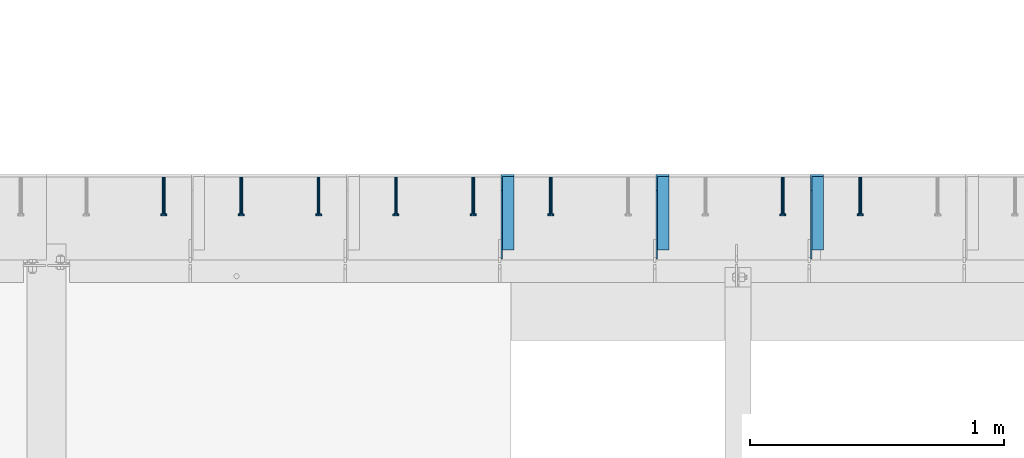
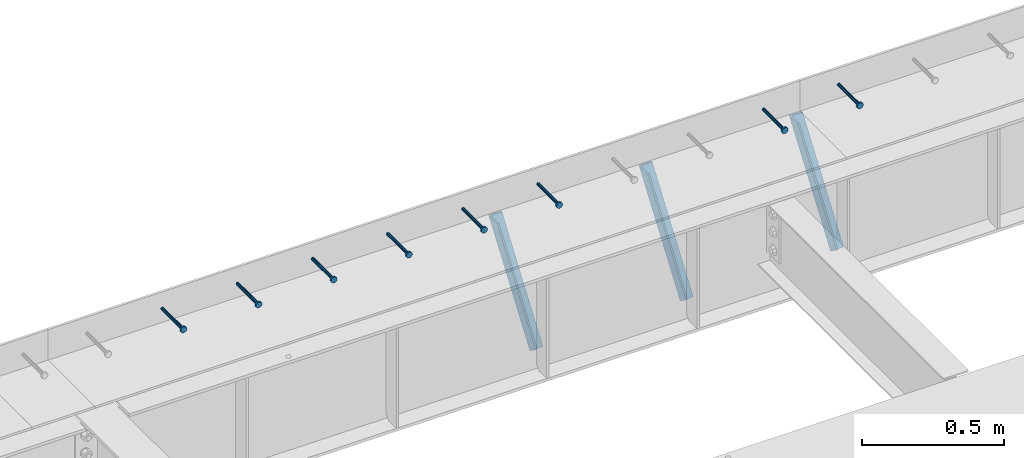
# One storey, part 1342 of 1763: 8 beams, 3 members, 9 elements without a shape of their own.
"""IFC2X3 building model written with IfcOpenShell, lengths in millimetres."""

from ifc_helpers import new_model, si_unit, frame, origin_with_axes, place, context, subcontext, project, spatial, faceted_brep, material, type_object, element, aggregate, save


model = new_model("IFC2X3")

# Units and contexts
model_context = context("Model", 3, precision=1e-05, world=origin_with_axes())
body_context = subcontext(model_context, "Body", "Model", "MODEL_VIEW")
ifc_project = project(units=[si_unit("LENGTHUNIT", "METRE", prefix="MILLI"), si_unit("AREAUNIT", "SQUARE_METRE"), si_unit("VOLUMEUNIT", "CUBIC_METRE"), si_unit("MASSUNIT", "GRAM", prefix="KILO"), si_unit("TIMEUNIT", "SECOND"), si_unit("PLANEANGLEUNIT", "RADIAN"), si_unit("SOLIDANGLEUNIT", "STERADIAN"), si_unit("THERMODYNAMICTEMPERATUREUNIT", "DEGREE_CELSIUS"), si_unit("LUMINOUSINTENSITYUNIT", "LUMEN")], contexts=[model_context])

# Site, building, storey
site_placement = place(None, origin_with_axes())
site = spatial("IfcSite", under=ifc_project, at=site_placement, CompositionType="ELEMENT")
building_placement = place(site_placement, origin_with_axes())
building = spatial("IfcBuilding", under=site, at=building_placement, Name="Undefined", CompositionType="ELEMENT")
storey_placement = place(building_placement, origin_with_axes())
storey = spatial("IfcBuildingStorey", under=building, at=storey_placement, Name="Undefined", CompositionType="ELEMENT", Elevation=0.0)

# Assembly, beam
assembly_1_placement = place(storey_placement, origin_with_axes())
assembly_1 = element("IfcElementAssembly", 1, at=assembly_1_placement, inside=storey, Name="HEADED STUD ANCHOR", AssemblyPlace="NOTDEFINED", PredefinedType="RIGID_FRAME")
ifc_material_1 = material(Name="STEEL/A108")
beam_type = type_object("IfcBeamType", PredefinedType="NOTDEFINED")
beam_1_placement = place(assembly_1_placement, frame((-69285.8747736983, 53984.5250183106, 5264.23140606069), z_axis=(0.0, 0.0, 1.0), x_axis=(0.0, -1.0, 0.0)))
beam_1 = element("IfcBeam", 2, at=beam_1_placement, type_object=beam_type, material=ifc_material_1, Name="HEADED STUD ANCHOR", context=body_context, shape_type="Brep", body=[
    faceted_brep([(0.0, -3.1800000667572, 5.5), (0.0, -5.5, 3.1800000667572), (141.732000000002, -5.5, 3.1800000667572), (141.732000000002, -3.1800000667572, 5.5), (0.0, -6.34999999999491, 1.45519152283669e-11), (141.732000000002, -6.34999990463257, 0.0), (0.0, -5.5, -3.1800000667572), (141.732000000002, -5.5, -3.1800000667572), (0.0, -3.1800000667572, -5.5), (141.732000000002, -3.1800000667572, -5.5), (0.0, 0.0, -6.34999990463257), (141.732000000002, 0.0, -6.34999990463257), (0.0, 3.1800000667572, -5.5), (141.732000000002, 3.1800000667572, -5.5), (0.0, 5.5, -3.1800000667572), (141.732000000002, 5.5, -3.1800000667572), (0.0, 6.34999999999491, -2.91038304567337e-11), (141.732000000002, 6.34999990463257, 0.0), (0.0, 5.5, 3.1800000667572), (141.732000000002, 5.5, 3.1800000667572), (0.0, 3.1800000667572, 5.5), (141.732000000002, 3.1800000667572, 5.5), (0.0, 0.0, 6.34999990463257), (141.732000000002, 0.0, 6.34999990463257), (144.780000000001, -10.9899997711182, 6.34999990463257), (144.780000000001, -6.34000015258789, 10.9899997711182), (144.780000000001, -12.6999998092651, 0.0), (144.780000000001, -10.9899997711182, -6.34999990463257), (144.780000000001, -6.34000015258789, -10.9899997711182), (144.780000000001, 0.0, -12.6899995803833), (144.780000000001, 6.34000015258789, -10.9899997711182), (144.780000000001, 10.9899997711182, -6.34999990463257), (144.780000000001, 12.6999998092651, 0.0), (144.780000000001, 10.9899997711182, 6.34999990463257), (144.780000000001, 6.34000015258789, 10.9899997711182), (144.780000000001, 0.0, 12.6899995803833), (152.400000000001, -10.9899997711182, 6.34999990463257), (152.400000000001, -6.34000015258789, 10.9899997711182), (152.400000000001, -12.6999998092651, 0.0), (152.400000000001, -10.9899997711182, -6.34999990463257), (152.400000000001, -6.34000015258789, -10.9899997711182), (152.400000000001, 0.0, -12.6899995803833), (152.400000000001, 6.34000015258789, -10.9899997711182), (152.400000000001, 10.9899997711182, -6.34999990463257), (152.400000000001, 12.6999998092651, 0.0), (152.400000000001, 10.9899997711182, 6.34999990463257), (152.400000000001, 6.34000015258789, 10.9899997711182), (152.400000000001, 0.0, 12.6899995803833)], [[[0, 1, 2, 3]], [[1, 4, 5, 2]], [[4, 6, 7, 5]], [[6, 8, 9, 7]], [[8, 10, 11, 9]], [[10, 12, 13, 11]], [[12, 14, 15, 13]], [[14, 16, 17, 15]], [[16, 18, 19, 17]], [[18, 20, 21, 19]], [[20, 22, 23, 21]], [[22, 0, 3, 23]], [[22, 20, 18, 16, 14, 12, 10, 8, 6, 4, 1, 0]], [[3, 2, 24, 25]], [[2, 5, 26, 24]], [[5, 7, 27, 26]], [[7, 9, 28, 27]], [[9, 11, 29, 28]], [[11, 13, 30, 29]], [[13, 15, 31, 30]], [[15, 17, 32, 31]], [[17, 19, 33, 32]], [[19, 21, 34, 33]], [[21, 23, 35, 34]], [[23, 3, 25, 35]], [[25, 24, 36, 37]], [[24, 26, 38, 36]], [[26, 27, 39, 38]], [[27, 28, 40, 39]], [[28, 29, 41, 40]], [[29, 30, 42, 41]], [[30, 31, 43, 42]], [[31, 32, 44, 43]], [[32, 33, 45, 44]], [[33, 34, 46, 45]], [[34, 35, 47, 46]], [[35, 25, 37, 47]], [[38, 39, 40, 41, 42, 43, 44, 45, 46, 47, 37, 36]]]),
])
aggregate(assembly_1, [beam_1])

assembly_2_placement = place(storey_placement, origin_with_axes())
assembly_2 = element("IfcElementAssembly", 3, at=assembly_2_placement, inside=storey, Name="HEADED STUD ANCHOR", AssemblyPlace="NOTDEFINED", PredefinedType="RIGID_FRAME")
beam_2_placement = place(assembly_2_placement, frame((-69590.6747736984, 53984.5250183106, 5264.23140606069), z_axis=(0.0, 0.0, 1.0), x_axis=(0.0, -1.0, 0.0)))
beam_2 = element("IfcBeam", 4, at=beam_2_placement, type_object=beam_type, material=ifc_material_1, Name="HEADED STUD ANCHOR", context=body_context, shape_type="Brep", body=[
    faceted_brep([(0.0, -3.1800000667572, 5.5), (0.0, -5.5, 3.1800000667572), (141.732000000002, -5.5, 3.1800000667572), (141.732000000002, -3.1800000667572, 5.5), (0.0, -6.34999999999491, 1.45519152283669e-11), (141.732000000002, -6.34999990463257, 0.0), (0.0, -5.5, -3.1800000667572), (141.732000000002, -5.5, -3.1800000667572), (0.0, -3.1800000667572, -5.5), (141.732000000002, -3.1800000667572, -5.5), (0.0, 0.0, -6.34999990463257), (141.732000000002, 0.0, -6.34999990463257), (0.0, 3.1800000667572, -5.5), (141.732000000002, 3.1800000667572, -5.5), (0.0, 5.5, -3.1800000667572), (141.732000000002, 5.5, -3.1800000667572), (0.0, 6.34999999999491, -2.91038304567337e-11), (141.732000000002, 6.34999990463257, 0.0), (0.0, 5.5, 3.1800000667572), (141.732000000002, 5.5, 3.1800000667572), (0.0, 3.1800000667572, 5.5), (141.732000000002, 3.1800000667572, 5.5), (0.0, 0.0, 6.34999990463257), (141.732000000002, 0.0, 6.34999990463257), (144.780000000001, -10.9899997711182, 6.34999990463257), (144.780000000001, -6.34000015258789, 10.9899997711182), (144.780000000001, -12.6999998092651, 0.0), (144.780000000001, -10.9899997711182, -6.34999990463257), (144.780000000001, -6.34000015258789, -10.9899997711182), (144.780000000001, 0.0, -12.6899995803833), (144.780000000001, 6.34000015258789, -10.9899997711182), (144.780000000001, 10.9899997711182, -6.34999990463257), (144.780000000001, 12.6999998092651, 0.0), (144.780000000001, 10.9899997711182, 6.34999990463257), (144.780000000001, 6.34000015258789, 10.9899997711182), (144.780000000001, 0.0, 12.6899995803833), (152.400000000001, -10.9899997711182, 6.34999990463257), (152.400000000001, -6.34000015258789, 10.9899997711182), (152.400000000001, -12.6999998092651, 0.0), (152.400000000001, -10.9899997711182, -6.34999990463257), (152.400000000001, -6.34000015258789, -10.9899997711182), (152.400000000001, 0.0, -12.6899995803833), (152.400000000001, 6.34000015258789, -10.9899997711182), (152.400000000001, 10.9899997711182, -6.34999990463257), (152.400000000001, 12.6999998092651, 0.0), (152.400000000001, 10.9899997711182, 6.34999990463257), (152.400000000001, 6.34000015258789, 10.9899997711182), (152.400000000001, 0.0, 12.6899995803833)], [[[0, 1, 2, 3]], [[1, 4, 5, 2]], [[4, 6, 7, 5]], [[6, 8, 9, 7]], [[8, 10, 11, 9]], [[10, 12, 13, 11]], [[12, 14, 15, 13]], [[14, 16, 17, 15]], [[16, 18, 19, 17]], [[18, 20, 21, 19]], [[20, 22, 23, 21]], [[22, 0, 3, 23]], [[22, 20, 18, 16, 14, 12, 10, 8, 6, 4, 1, 0]], [[3, 2, 24, 25]], [[2, 5, 26, 24]], [[5, 7, 27, 26]], [[7, 9, 28, 27]], [[9, 11, 29, 28]], [[11, 13, 30, 29]], [[13, 15, 31, 30]], [[15, 17, 32, 31]], [[17, 19, 33, 32]], [[19, 21, 34, 33]], [[21, 23, 35, 34]], [[23, 3, 25, 35]], [[25, 24, 36, 37]], [[24, 26, 38, 36]], [[26, 27, 39, 38]], [[27, 28, 40, 39]], [[28, 29, 41, 40]], [[29, 30, 42, 41]], [[30, 31, 43, 42]], [[31, 32, 44, 43]], [[32, 33, 45, 44]], [[33, 34, 46, 45]], [[34, 35, 47, 46]], [[35, 25, 37, 47]], [[38, 39, 40, 41, 42, 43, 44, 45, 46, 47, 37, 36]]]),
])
aggregate(assembly_2, [beam_2])

assembly_3_placement = place(storey_placement, origin_with_axes())
assembly_3 = element("IfcElementAssembly", 5, at=assembly_3_placement, inside=storey, Name="HEADED STUD ANCHOR", AssemblyPlace="NOTDEFINED", PredefinedType="RIGID_FRAME")
beam_3_placement = place(assembly_3_placement, frame((-70505.0747736983, 53984.5250183106, 5264.23140606069), z_axis=(0.0, 0.0, 1.0), x_axis=(0.0, -1.0, 0.0)))
beam_3 = element("IfcBeam", 6, at=beam_3_placement, type_object=beam_type, material=ifc_material_1, Name="HEADED STUD ANCHOR", context=body_context, shape_type="Brep", body=[
    faceted_brep([(0.0, -3.1800000667572, 5.5), (0.0, -5.5, 3.1800000667572), (141.732000000002, -5.5, 3.1800000667572), (141.732000000002, -3.1800000667572, 5.5), (0.0, -6.34999999999491, 1.45519152283669e-11), (141.732000000002, -6.34999990463257, 0.0), (0.0, -5.5, -3.1800000667572), (141.732000000002, -5.5, -3.1800000667572), (0.0, -3.1800000667572, -5.5), (141.732000000002, -3.1800000667572, -5.5), (0.0, 0.0, -6.34999990463257), (141.732000000002, 0.0, -6.34999990463257), (0.0, 3.1800000667572, -5.5), (141.732000000002, 3.1800000667572, -5.5), (0.0, 5.5, -3.1800000667572), (141.732000000002, 5.5, -3.1800000667572), (0.0, 6.34999999999491, -2.91038304567337e-11), (141.732000000002, 6.34999990463257, 0.0), (0.0, 5.5, 3.1800000667572), (141.732000000002, 5.5, 3.1800000667572), (0.0, 3.1800000667572, 5.5), (141.732000000002, 3.1800000667572, 5.5), (0.0, 0.0, 6.34999990463257), (141.732000000002, 0.0, 6.34999990463257), (144.780000000001, -10.9899997711182, 6.34999990463257), (144.780000000001, -6.34000015258789, 10.9899997711182), (144.780000000001, -12.6999998092651, 0.0), (144.780000000001, -10.9899997711182, -6.34999990463257), (144.780000000001, -6.34000015258789, -10.9899997711182), (144.780000000001, 0.0, -12.6899995803833), (144.780000000001, 6.34000015258789, -10.9899997711182), (144.780000000001, 10.9899997711182, -6.34999990463257), (144.780000000001, 12.6999998092651, 0.0), (144.780000000001, 10.9899997711182, 6.34999990463257), (144.780000000001, 6.34000015258789, 10.9899997711182), (144.780000000001, 0.0, 12.6899995803833), (152.400000000001, -10.9899997711182, 6.34999990463257), (152.400000000001, -6.34000015258789, 10.9899997711182), (152.400000000001, -12.6999998092651, 0.0), (152.400000000001, -10.9899997711182, -6.34999990463257), (152.400000000001, -6.34000015258789, -10.9899997711182), (152.400000000001, 0.0, -12.6899995803833), (152.400000000001, 6.34000015258789, -10.9899997711182), (152.400000000001, 10.9899997711182, -6.34999990463257), (152.400000000001, 12.6999998092651, 0.0), (152.400000000001, 10.9899997711182, 6.34999990463257), (152.400000000001, 6.34000015258789, 10.9899997711182), (152.400000000001, 0.0, 12.6899995803833)], [[[0, 1, 2, 3]], [[1, 4, 5, 2]], [[4, 6, 7, 5]], [[6, 8, 9, 7]], [[8, 10, 11, 9]], [[10, 12, 13, 11]], [[12, 14, 15, 13]], [[14, 16, 17, 15]], [[16, 18, 19, 17]], [[18, 20, 21, 19]], [[20, 22, 23, 21]], [[22, 0, 3, 23]], [[22, 20, 18, 16, 14, 12, 10, 8, 6, 4, 1, 0]], [[3, 2, 24, 25]], [[2, 5, 26, 24]], [[5, 7, 27, 26]], [[7, 9, 28, 27]], [[9, 11, 29, 28]], [[11, 13, 30, 29]], [[13, 15, 31, 30]], [[15, 17, 32, 31]], [[17, 19, 33, 32]], [[19, 21, 34, 33]], [[21, 23, 35, 34]], [[23, 3, 25, 35]], [[25, 24, 36, 37]], [[24, 26, 38, 36]], [[26, 27, 39, 38]], [[27, 28, 40, 39]], [[28, 29, 41, 40]], [[29, 30, 42, 41]], [[30, 31, 43, 42]], [[31, 32, 44, 43]], [[32, 33, 45, 44]], [[33, 34, 46, 45]], [[34, 35, 47, 46]], [[35, 25, 37, 47]], [[38, 39, 40, 41, 42, 43, 44, 45, 46, 47, 37, 36]]]),
])
aggregate(assembly_3, [beam_3])

assembly_4_placement = place(storey_placement, origin_with_axes())
assembly_4 = element("IfcElementAssembly", 7, at=assembly_4_placement, inside=storey, Name="HEADED STUD ANCHOR", AssemblyPlace="NOTDEFINED", PredefinedType="RIGID_FRAME")
beam_4_placement = place(assembly_4_placement, frame((-70809.8747736983, 53984.5250183106, 5264.23140606069), z_axis=(0.0, 0.0, 1.0), x_axis=(0.0, -1.0, 0.0)))
beam_4 = element("IfcBeam", 8, at=beam_4_placement, type_object=beam_type, material=ifc_material_1, Name="HEADED STUD ANCHOR", context=body_context, shape_type="Brep", body=[
    faceted_brep([(0.0, -3.1800000667572, 5.5), (0.0, -5.5, 3.1800000667572), (141.732000000002, -5.5, 3.1800000667572), (141.732000000002, -3.1800000667572, 5.5), (0.0, -6.34999999999491, 1.45519152283669e-11), (141.732000000002, -6.34999990463257, 0.0), (0.0, -5.5, -3.1800000667572), (141.732000000002, -5.5, -3.1800000667572), (0.0, -3.1800000667572, -5.5), (141.732000000002, -3.1800000667572, -5.5), (0.0, 0.0, -6.34999990463257), (141.732000000002, 0.0, -6.34999990463257), (0.0, 3.1800000667572, -5.5), (141.732000000002, 3.1800000667572, -5.5), (0.0, 5.5, -3.1800000667572), (141.732000000002, 5.5, -3.1800000667572), (0.0, 6.34999999999491, -2.91038304567337e-11), (141.732000000002, 6.34999990463257, 0.0), (0.0, 5.5, 3.1800000667572), (141.732000000002, 5.5, 3.1800000667572), (0.0, 3.1800000667572, 5.5), (141.732000000002, 3.1800000667572, 5.5), (0.0, 0.0, 6.34999990463257), (141.732000000002, 0.0, 6.34999990463257), (144.780000000001, -10.9899997711182, 6.34999990463257), (144.780000000001, -6.34000015258789, 10.9899997711182), (144.780000000001, -12.6999998092651, 0.0), (144.780000000001, -10.9899997711182, -6.34999990463257), (144.780000000001, -6.34000015258789, -10.9899997711182), (144.780000000001, 0.0, -12.6899995803833), (144.780000000001, 6.34000015258789, -10.9899997711182), (144.780000000001, 10.9899997711182, -6.34999990463257), (144.780000000001, 12.6999998092651, 0.0), (144.780000000001, 10.9899997711182, 6.34999990463257), (144.780000000001, 6.34000015258789, 10.9899997711182), (144.780000000001, 0.0, 12.6899995803833), (152.400000000001, -10.9899997711182, 6.34999990463257), (152.400000000001, -6.34000015258789, 10.9899997711182), (152.400000000001, -12.6999998092651, 0.0), (152.400000000001, -10.9899997711182, -6.34999990463257), (152.400000000001, -6.34000015258789, -10.9899997711182), (152.400000000001, 0.0, -12.6899995803833), (152.400000000001, 6.34000015258789, -10.9899997711182), (152.400000000001, 10.9899997711182, -6.34999990463257), (152.400000000001, 12.6999998092651, 0.0), (152.400000000001, 10.9899997711182, 6.34999990463257), (152.400000000001, 6.34000015258789, 10.9899997711182), (152.400000000001, 0.0, 12.6899995803833)], [[[0, 1, 2, 3]], [[1, 4, 5, 2]], [[4, 6, 7, 5]], [[6, 8, 9, 7]], [[8, 10, 11, 9]], [[10, 12, 13, 11]], [[12, 14, 15, 13]], [[14, 16, 17, 15]], [[16, 18, 19, 17]], [[18, 20, 21, 19]], [[20, 22, 23, 21]], [[22, 0, 3, 23]], [[22, 20, 18, 16, 14, 12, 10, 8, 6, 4, 1, 0]], [[3, 2, 24, 25]], [[2, 5, 26, 24]], [[5, 7, 27, 26]], [[7, 9, 28, 27]], [[9, 11, 29, 28]], [[11, 13, 30, 29]], [[13, 15, 31, 30]], [[15, 17, 32, 31]], [[17, 19, 33, 32]], [[19, 21, 34, 33]], [[21, 23, 35, 34]], [[23, 3, 25, 35]], [[25, 24, 36, 37]], [[24, 26, 38, 36]], [[26, 27, 39, 38]], [[27, 28, 40, 39]], [[28, 29, 41, 40]], [[29, 30, 42, 41]], [[30, 31, 43, 42]], [[31, 32, 44, 43]], [[32, 33, 45, 44]], [[33, 34, 46, 45]], [[34, 35, 47, 46]], [[35, 25, 37, 47]], [[38, 39, 40, 41, 42, 43, 44, 45, 46, 47, 37, 36]]]),
])
aggregate(assembly_4, [beam_4])

assembly_5_placement = place(storey_placement, origin_with_axes())
assembly_5 = element("IfcElementAssembly", 9, at=assembly_5_placement, inside=storey, Name="HEADED STUD ANCHOR", AssemblyPlace="NOTDEFINED", PredefinedType="RIGID_FRAME")
beam_5_placement = place(assembly_5_placement, frame((-71114.6747736984, 53984.5250183106, 5264.23140606069), z_axis=(0.0, 0.0, 1.0), x_axis=(0.0, -1.0, 0.0)))
beam_5 = element("IfcBeam", 10, at=beam_5_placement, type_object=beam_type, material=ifc_material_1, Name="HEADED STUD ANCHOR", context=body_context, shape_type="Brep", body=[
    faceted_brep([(0.0, -3.1800000667572, 5.5), (0.0, -5.5, 3.1800000667572), (141.732000000002, -5.5, 3.1800000667572), (141.732000000002, -3.1800000667572, 5.5), (0.0, -6.34999999999491, 1.45519152283669e-11), (141.732000000002, -6.34999990463257, 0.0), (0.0, -5.5, -3.1800000667572), (141.732000000002, -5.5, -3.1800000667572), (0.0, -3.1800000667572, -5.5), (141.732000000002, -3.1800000667572, -5.5), (0.0, 0.0, -6.34999990463257), (141.732000000002, 0.0, -6.34999990463257), (0.0, 3.1800000667572, -5.5), (141.732000000002, 3.1800000667572, -5.5), (0.0, 5.5, -3.1800000667572), (141.732000000002, 5.5, -3.1800000667572), (0.0, 6.34999999999491, -2.91038304567337e-11), (141.732000000002, 6.34999990463257, 0.0), (0.0, 5.5, 3.1800000667572), (141.732000000002, 5.5, 3.1800000667572), (0.0, 3.1800000667572, 5.5), (141.732000000002, 3.1800000667572, 5.5), (0.0, 0.0, 6.34999990463257), (141.732000000002, 0.0, 6.34999990463257), (144.780000000001, -10.9899997711182, 6.34999990463257), (144.780000000001, -6.34000015258789, 10.9899997711182), (144.780000000001, -12.6999998092651, 0.0), (144.780000000001, -10.9899997711182, -6.34999990463257), (144.780000000001, -6.34000015258789, -10.9899997711182), (144.780000000001, 0.0, -12.6899995803833), (144.780000000001, 6.34000015258789, -10.9899997711182), (144.780000000001, 10.9899997711182, -6.34999990463257), (144.780000000001, 12.6999998092651, 0.0), (144.780000000001, 10.9899997711182, 6.34999990463257), (144.780000000001, 6.34000015258789, 10.9899997711182), (144.780000000001, 0.0, 12.6899995803833), (152.400000000001, -10.9899997711182, 6.34999990463257), (152.400000000001, -6.34000015258789, 10.9899997711182), (152.400000000001, -12.6999998092651, 0.0), (152.400000000001, -10.9899997711182, -6.34999990463257), (152.400000000001, -6.34000015258789, -10.9899997711182), (152.400000000001, 0.0, -12.6899995803833), (152.400000000001, 6.34000015258789, -10.9899997711182), (152.400000000001, 10.9899997711182, -6.34999990463257), (152.400000000001, 12.6999998092651, 0.0), (152.400000000001, 10.9899997711182, 6.34999990463257), (152.400000000001, 6.34000015258789, 10.9899997711182), (152.400000000001, 0.0, 12.6899995803833)], [[[0, 1, 2, 3]], [[1, 4, 5, 2]], [[4, 6, 7, 5]], [[6, 8, 9, 7]], [[8, 10, 11, 9]], [[10, 12, 13, 11]], [[12, 14, 15, 13]], [[14, 16, 17, 15]], [[16, 18, 19, 17]], [[18, 20, 21, 19]], [[20, 22, 23, 21]], [[22, 0, 3, 23]], [[22, 20, 18, 16, 14, 12, 10, 8, 6, 4, 1, 0]], [[3, 2, 24, 25]], [[2, 5, 26, 24]], [[5, 7, 27, 26]], [[7, 9, 28, 27]], [[9, 11, 29, 28]], [[11, 13, 30, 29]], [[13, 15, 31, 30]], [[15, 17, 32, 31]], [[17, 19, 33, 32]], [[19, 21, 34, 33]], [[21, 23, 35, 34]], [[23, 3, 25, 35]], [[25, 24, 36, 37]], [[24, 26, 38, 36]], [[26, 27, 39, 38]], [[27, 28, 40, 39]], [[28, 29, 41, 40]], [[29, 30, 42, 41]], [[30, 31, 43, 42]], [[31, 32, 44, 43]], [[32, 33, 45, 44]], [[33, 34, 46, 45]], [[34, 35, 47, 46]], [[35, 25, 37, 47]], [[38, 39, 40, 41, 42, 43, 44, 45, 46, 47, 37, 36]]]),
])
aggregate(assembly_5, [beam_5])

assembly_6_placement = place(storey_placement, origin_with_axes())
assembly_6 = element("IfcElementAssembly", 11, at=assembly_6_placement, inside=storey, Name="HEADED STUD ANCHOR", AssemblyPlace="NOTDEFINED", PredefinedType="RIGID_FRAME")
beam_6_placement = place(assembly_6_placement, frame((-71419.4747736984, 53984.5250183106, 5264.23140606069), z_axis=(0.0, 0.0, 1.0), x_axis=(0.0, -1.0, 0.0)))
beam_6 = element("IfcBeam", 12, at=beam_6_placement, type_object=beam_type, material=ifc_material_1, Name="HEADED STUD ANCHOR", context=body_context, shape_type="Brep", body=[
    faceted_brep([(0.0, -3.1800000667572, 5.5), (0.0, -5.5, 3.1800000667572), (141.732000000002, -5.5, 3.1800000667572), (141.732000000002, -3.1800000667572, 5.5), (0.0, -6.34999999999491, 1.45519152283669e-11), (141.732000000002, -6.34999990463257, 0.0), (0.0, -5.5, -3.1800000667572), (141.732000000002, -5.5, -3.1800000667572), (0.0, -3.1800000667572, -5.5), (141.732000000002, -3.1800000667572, -5.5), (0.0, 0.0, -6.34999990463257), (141.732000000002, 0.0, -6.34999990463257), (0.0, 3.1800000667572, -5.5), (141.732000000002, 3.1800000667572, -5.5), (0.0, 5.5, -3.1800000667572), (141.732000000002, 5.5, -3.1800000667572), (0.0, 6.34999999999491, -2.91038304567337e-11), (141.732000000002, 6.34999990463257, 0.0), (0.0, 5.5, 3.1800000667572), (141.732000000002, 5.5, 3.1800000667572), (0.0, 3.1800000667572, 5.5), (141.732000000002, 3.1800000667572, 5.5), (0.0, 0.0, 6.34999990463257), (141.732000000002, 0.0, 6.34999990463257), (144.780000000001, -10.9899997711182, 6.34999990463257), (144.780000000001, -6.34000015258789, 10.9899997711182), (144.780000000001, -12.6999998092651, 0.0), (144.780000000001, -10.9899997711182, -6.34999990463257), (144.780000000001, -6.34000015258789, -10.9899997711182), (144.780000000001, 0.0, -12.6899995803833), (144.780000000001, 6.34000015258789, -10.9899997711182), (144.780000000001, 10.9899997711182, -6.34999990463257), (144.780000000001, 12.6999998092651, 0.0), (144.780000000001, 10.9899997711182, 6.34999990463257), (144.780000000001, 6.34000015258789, 10.9899997711182), (144.780000000001, 0.0, 12.6899995803833), (152.400000000001, -10.9899997711182, 6.34999990463257), (152.400000000001, -6.34000015258789, 10.9899997711182), (152.400000000001, -12.6999998092651, 0.0), (152.400000000001, -10.9899997711182, -6.34999990463257), (152.400000000001, -6.34000015258789, -10.9899997711182), (152.400000000001, 0.0, -12.6899995803833), (152.400000000001, 6.34000015258789, -10.9899997711182), (152.400000000001, 10.9899997711182, -6.34999990463257), (152.400000000001, 12.6999998092651, 0.0), (152.400000000001, 10.9899997711182, 6.34999990463257), (152.400000000001, 6.34000015258789, 10.9899997711182), (152.400000000001, 0.0, 12.6899995803833)], [[[0, 1, 2, 3]], [[1, 4, 5, 2]], [[4, 6, 7, 5]], [[6, 8, 9, 7]], [[8, 10, 11, 9]], [[10, 12, 13, 11]], [[12, 14, 15, 13]], [[14, 16, 17, 15]], [[16, 18, 19, 17]], [[18, 20, 21, 19]], [[20, 22, 23, 21]], [[22, 0, 3, 23]], [[22, 20, 18, 16, 14, 12, 10, 8, 6, 4, 1, 0]], [[3, 2, 24, 25]], [[2, 5, 26, 24]], [[5, 7, 27, 26]], [[7, 9, 28, 27]], [[9, 11, 29, 28]], [[11, 13, 30, 29]], [[13, 15, 31, 30]], [[15, 17, 32, 31]], [[17, 19, 33, 32]], [[19, 21, 34, 33]], [[21, 23, 35, 34]], [[23, 3, 25, 35]], [[25, 24, 36, 37]], [[24, 26, 38, 36]], [[26, 27, 39, 38]], [[27, 28, 40, 39]], [[28, 29, 41, 40]], [[29, 30, 42, 41]], [[30, 31, 43, 42]], [[31, 32, 44, 43]], [[32, 33, 45, 44]], [[33, 34, 46, 45]], [[34, 35, 47, 46]], [[35, 25, 37, 47]], [[38, 39, 40, 41, 42, 43, 44, 45, 46, 47, 37, 36]]]),
])
aggregate(assembly_6, [beam_6])

assembly_7_placement = place(storey_placement, origin_with_axes())
assembly_7 = element("IfcElementAssembly", 13, at=assembly_7_placement, inside=storey, Name="HEADED STUD ANCHOR", AssemblyPlace="NOTDEFINED", PredefinedType="RIGID_FRAME")
beam_7_placement = place(assembly_7_placement, frame((-71724.2747736983, 53984.5250183106, 5264.23140606069), z_axis=(0.0, 0.0, 1.0), x_axis=(0.0, -1.0, 0.0)))
beam_7 = element("IfcBeam", 14, at=beam_7_placement, type_object=beam_type, material=ifc_material_1, Name="HEADED STUD ANCHOR", context=body_context, shape_type="Brep", body=[
    faceted_brep([(0.0, -3.1800000667572, 5.5), (0.0, -5.5, 3.1800000667572), (141.732000000002, -5.5, 3.1800000667572), (141.732000000002, -3.1800000667572, 5.5), (0.0, -6.34999999999491, 1.45519152283669e-11), (141.732000000002, -6.34999990463257, 0.0), (0.0, -5.5, -3.1800000667572), (141.732000000002, -5.5, -3.1800000667572), (0.0, -3.1800000667572, -5.5), (141.732000000002, -3.1800000667572, -5.5), (0.0, 0.0, -6.34999990463257), (141.732000000002, 0.0, -6.34999990463257), (0.0, 3.1800000667572, -5.5), (141.732000000002, 3.1800000667572, -5.5), (0.0, 5.5, -3.1800000667572), (141.732000000002, 5.5, -3.1800000667572), (0.0, 6.34999999999491, -2.91038304567337e-11), (141.732000000002, 6.34999990463257, 0.0), (0.0, 5.5, 3.1800000667572), (141.732000000002, 5.5, 3.1800000667572), (0.0, 3.1800000667572, 5.5), (141.732000000002, 3.1800000667572, 5.5), (0.0, 0.0, 6.34999990463257), (141.732000000002, 0.0, 6.34999990463257), (144.780000000001, -10.9899997711182, 6.34999990463257), (144.780000000001, -6.34000015258789, 10.9899997711182), (144.780000000001, -12.6999998092651, 0.0), (144.780000000001, -10.9899997711182, -6.34999990463257), (144.780000000001, -6.34000015258789, -10.9899997711182), (144.780000000001, 0.0, -12.6899995803833), (144.780000000001, 6.34000015258789, -10.9899997711182), (144.780000000001, 10.9899997711182, -6.34999990463257), (144.780000000001, 12.6999998092651, 0.0), (144.780000000001, 10.9899997711182, 6.34999990463257), (144.780000000001, 6.34000015258789, 10.9899997711182), (144.780000000001, 0.0, 12.6899995803833), (152.400000000001, -10.9899997711182, 6.34999990463257), (152.400000000001, -6.34000015258789, 10.9899997711182), (152.400000000001, -12.6999998092651, 0.0), (152.400000000001, -10.9899997711182, -6.34999990463257), (152.400000000001, -6.34000015258789, -10.9899997711182), (152.400000000001, 0.0, -12.6899995803833), (152.400000000001, 6.34000015258789, -10.9899997711182), (152.400000000001, 10.9899997711182, -6.34999990463257), (152.400000000001, 12.6999998092651, 0.0), (152.400000000001, 10.9899997711182, 6.34999990463257), (152.400000000001, 6.34000015258789, 10.9899997711182), (152.400000000001, 0.0, 12.6899995803833)], [[[0, 1, 2, 3]], [[1, 4, 5, 2]], [[4, 6, 7, 5]], [[6, 8, 9, 7]], [[8, 10, 11, 9]], [[10, 12, 13, 11]], [[12, 14, 15, 13]], [[14, 16, 17, 15]], [[16, 18, 19, 17]], [[18, 20, 21, 19]], [[20, 22, 23, 21]], [[22, 0, 3, 23]], [[22, 20, 18, 16, 14, 12, 10, 8, 6, 4, 1, 0]], [[3, 2, 24, 25]], [[2, 5, 26, 24]], [[5, 7, 27, 26]], [[7, 9, 28, 27]], [[9, 11, 29, 28]], [[11, 13, 30, 29]], [[13, 15, 31, 30]], [[15, 17, 32, 31]], [[17, 19, 33, 32]], [[19, 21, 34, 33]], [[21, 23, 35, 34]], [[23, 3, 25, 35]], [[25, 24, 36, 37]], [[24, 26, 38, 36]], [[26, 27, 39, 38]], [[27, 28, 40, 39]], [[28, 29, 41, 40]], [[29, 30, 42, 41]], [[30, 31, 43, 42]], [[31, 32, 44, 43]], [[32, 33, 45, 44]], [[33, 34, 46, 45]], [[34, 35, 47, 46]], [[35, 25, 37, 47]], [[38, 39, 40, 41, 42, 43, 44, 45, 46, 47, 37, 36]]]),
])
aggregate(assembly_7, [beam_7])

assembly_8_placement = place(storey_placement, origin_with_axes())
assembly_8 = element("IfcElementAssembly", 15, at=assembly_8_placement, inside=storey, Name="HEADED STUD ANCHOR", AssemblyPlace="NOTDEFINED", PredefinedType="RIGID_FRAME")
beam_8_placement = place(assembly_8_placement, frame((-72029.0747736983, 53984.5250183106, 5264.23140606069), z_axis=(0.0, 0.0, 1.0), x_axis=(0.0, -1.0, 0.0)))
beam_8 = element("IfcBeam", 16, at=beam_8_placement, type_object=beam_type, material=ifc_material_1, Name="HEADED STUD ANCHOR", context=body_context, shape_type="Brep", body=[
    faceted_brep([(0.0, -3.1800000667572, 5.5), (0.0, -5.5, 3.1800000667572), (141.732000000002, -5.5, 3.1800000667572), (141.732000000002, -3.1800000667572, 5.5), (0.0, -6.34999999999491, 1.45519152283669e-11), (141.732000000002, -6.34999990463257, 0.0), (0.0, -5.5, -3.1800000667572), (141.732000000002, -5.5, -3.1800000667572), (0.0, -3.1800000667572, -5.5), (141.732000000002, -3.1800000667572, -5.5), (0.0, 0.0, -6.34999990463257), (141.732000000002, 0.0, -6.34999990463257), (0.0, 3.1800000667572, -5.5), (141.732000000002, 3.1800000667572, -5.5), (0.0, 5.5, -3.1800000667572), (141.732000000002, 5.5, -3.1800000667572), (0.0, 6.34999999999491, -2.91038304567337e-11), (141.732000000002, 6.34999990463257, 0.0), (0.0, 5.5, 3.1800000667572), (141.732000000002, 5.5, 3.1800000667572), (0.0, 3.1800000667572, 5.5), (141.732000000002, 3.1800000667572, 5.5), (0.0, 0.0, 6.34999990463257), (141.732000000002, 0.0, 6.34999990463257), (144.780000000001, -10.9899997711182, 6.34999990463257), (144.780000000001, -6.34000015258789, 10.9899997711182), (144.780000000001, -12.6999998092651, 0.0), (144.780000000001, -10.9899997711182, -6.34999990463257), (144.780000000001, -6.34000015258789, -10.9899997711182), (144.780000000001, 0.0, -12.6899995803833), (144.780000000001, 6.34000015258789, -10.9899997711182), (144.780000000001, 10.9899997711182, -6.34999990463257), (144.780000000001, 12.6999998092651, 0.0), (144.780000000001, 10.9899997711182, 6.34999990463257), (144.780000000001, 6.34000015258789, 10.9899997711182), (144.780000000001, 0.0, 12.6899995803833), (152.400000000001, -10.9899997711182, 6.34999990463257), (152.400000000001, -6.34000015258789, 10.9899997711182), (152.400000000001, -12.6999998092651, 0.0), (152.400000000001, -10.9899997711182, -6.34999990463257), (152.400000000001, -6.34000015258789, -10.9899997711182), (152.400000000001, 0.0, -12.6899995803833), (152.400000000001, 6.34000015258789, -10.9899997711182), (152.400000000001, 10.9899997711182, -6.34999990463257), (152.400000000001, 12.6999998092651, 0.0), (152.400000000001, 10.9899997711182, 6.34999990463257), (152.400000000001, 6.34000015258789, 10.9899997711182), (152.400000000001, 0.0, 12.6899995803833)], [[[0, 1, 2, 3]], [[1, 4, 5, 2]], [[4, 6, 7, 5]], [[6, 8, 9, 7]], [[8, 10, 11, 9]], [[10, 12, 13, 11]], [[12, 14, 15, 13]], [[14, 16, 17, 15]], [[16, 18, 19, 17]], [[18, 20, 21, 19]], [[20, 22, 23, 21]], [[22, 0, 3, 23]], [[22, 20, 18, 16, 14, 12, 10, 8, 6, 4, 1, 0]], [[3, 2, 24, 25]], [[2, 5, 26, 24]], [[5, 7, 27, 26]], [[7, 9, 28, 27]], [[9, 11, 29, 28]], [[11, 13, 30, 29]], [[13, 15, 31, 30]], [[15, 17, 32, 31]], [[17, 19, 33, 32]], [[19, 21, 34, 33]], [[21, 23, 35, 34]], [[23, 3, 25, 35]], [[25, 24, 36, 37]], [[24, 26, 38, 36]], [[26, 27, 39, 38]], [[27, 28, 40, 39]], [[28, 29, 41, 40]], [[29, 30, 42, 41]], [[30, 31, 43, 42]], [[31, 32, 44, 43]], [[32, 33, 45, 44]], [[33, 34, 46, 45]], [[34, 35, 47, 46]], [[35, 25, 37, 47]], [[38, 39, 40, 41, 42, 43, 44, 45, 46, 47, 37, 36]]]),
])
aggregate(assembly_8, [beam_8])

# Assembly, members
assembly_9_placement = place(storey_placement, origin_with_axes())
assembly_9 = element("IfcElementAssembly", 17, at=assembly_9_placement, inside=storey, Name="BEAM", AssemblyPlace="NOTDEFINED", PredefinedType="RIGID_FRAME")
ifc_material_2 = material(Name="STEEL/A36")
member_type = type_object("IfcMemberType", Name="L2X2X1/4", PredefinedType="NOTDEFINED")
member_1_placement = place(assembly_9_placement, frame((-70065.3372736984, 53682.7083833994, 4801.55161052496), z_axis=(0.0, -0.814117947745209, 0.580699549818259), x_axis=(0.0, 0.58069954981826, 0.814117947745209)))
member_1 = element("IfcMember", 18, at=member_1_placement, type_object=member_type, material=ifc_material_2, Name="ANGLE", ObjectType="L2X2X1/4", context=body_context, shape_type="Brep", body=[
    faceted_brep([(-1.45519152283669e-11, 25.4000000000015, -25.3999999999869), (1.45519152283669e-11, 25.4000000000015, 25.3999999999796), (464.304493432646, 25.4000000000015, 25.3999999991429), (500.539460322936, 25.4000000000015, -25.4000000009546), (1.45519152283669e-11, 19.0499999999993, 25.3999999999796), (464.304493432646, 19.0500000000029, 25.3999999991429), (-7.27595761418343e-12, 19.0499999999993, -19.0499999999956), (496.010089461648, 19.0500000000029, -19.0500000009415), (-7.27595761418343e-12, -25.4000000000015, -19.0499999999956), (496.010089461648, -25.4000000000015, -19.0500000009415), (-1.45519152283669e-11, -25.4000000000015, -25.3999999999869), (500.539460322936, -25.4000000000015, -25.4000000009546)], [[[0, 1, 2, 3]], [[1, 4, 5, 2]], [[4, 6, 7, 5]], [[6, 8, 9, 7]], [[8, 10, 11, 9]], [[10, 0, 3, 11]], [[5, 7, 9, 11, 3, 2]], [[10, 8, 6, 4, 1, 0]]]),
])
member_2_placement = place(assembly_9_placement, frame((-69455.7372736984, 53682.7083833993, 4801.55161052492), z_axis=(0.0, -0.814117947745209, 0.580699549818259), x_axis=(0.0, 0.58069954981826, 0.814117947745209)))
member_2 = element("IfcMember", 19, at=member_2_placement, type_object=member_type, material=ifc_material_2, Name="ANGLE", ObjectType="L2X2X1/4", context=body_context, shape_type="Brep", body=[
    faceted_brep([(-1.45519152283669e-11, 25.4000000000015, -25.3999999999869), (1.45519152283669e-11, 25.4000000000015, 25.3999999999796), (464.304493432646, 25.4000000000015, 25.3999999991429), (500.539460322936, 25.4000000000015, -25.4000000009546), (1.45519152283669e-11, 19.0499999999993, 25.3999999999796), (464.304493432646, 19.0500000000029, 25.3999999991429), (-7.27595761418343e-12, 19.0499999999993, -19.0499999999956), (496.010089461648, 19.0500000000029, -19.0500000009415), (-7.27595761418343e-12, -25.4000000000015, -19.0499999999956), (496.010089461648, -25.4000000000015, -19.0500000009415), (-1.45519152283669e-11, -25.4000000000015, -25.3999999999869), (500.539460322936, -25.4000000000015, -25.4000000009546)], [[[0, 1, 2, 3]], [[1, 4, 5, 2]], [[4, 6, 7, 5]], [[6, 8, 9, 7]], [[8, 10, 11, 9]], [[10, 0, 3, 11]], [[5, 7, 9, 11, 3, 2]], [[10, 8, 6, 4, 1, 0]]]),
])
member_3_placement = place(assembly_9_placement, frame((-70674.9372736984, 53682.7083833994, 4801.55161052496), z_axis=(0.0, -0.814117947745209, 0.580699549818259), x_axis=(0.0, 0.58069954981826, 0.814117947745209)))
member_3 = element("IfcMember", 20, at=member_3_placement, type_object=member_type, material=ifc_material_2, Name="ANGLE", ObjectType="L2X2X1/4", context=body_context, shape_type="Brep", body=[
    faceted_brep([(-1.45519152283669e-11, 25.4000000000015, -25.3999999999869), (1.45519152283669e-11, 25.4000000000015, 25.3999999999796), (464.304493432646, 25.4000000000015, 25.3999999991429), (500.539460322936, 25.4000000000015, -25.4000000009546), (1.45519152283669e-11, 19.0499999999993, 25.3999999999796), (464.304493432646, 19.0500000000029, 25.3999999991429), (-7.27595761418343e-12, 19.0499999999993, -19.0499999999956), (496.010089461648, 19.0500000000029, -19.0500000009415), (-7.27595761418343e-12, -25.4000000000015, -19.0499999999956), (496.010089461648, -25.4000000000015, -19.0500000009415), (-1.45519152283669e-11, -25.4000000000015, -25.3999999999869), (500.539460322936, -25.4000000000015, -25.4000000009546)], [[[0, 1, 2, 3]], [[1, 4, 5, 2]], [[4, 6, 7, 5]], [[6, 8, 9, 7]], [[8, 10, 11, 9]], [[10, 0, 3, 11]], [[5, 7, 9, 11, 3, 2]], [[10, 8, 6, 4, 1, 0]]]),
])
aggregate(assembly_9, [member_1, member_2, member_3])

save(model, "model.ifc")
